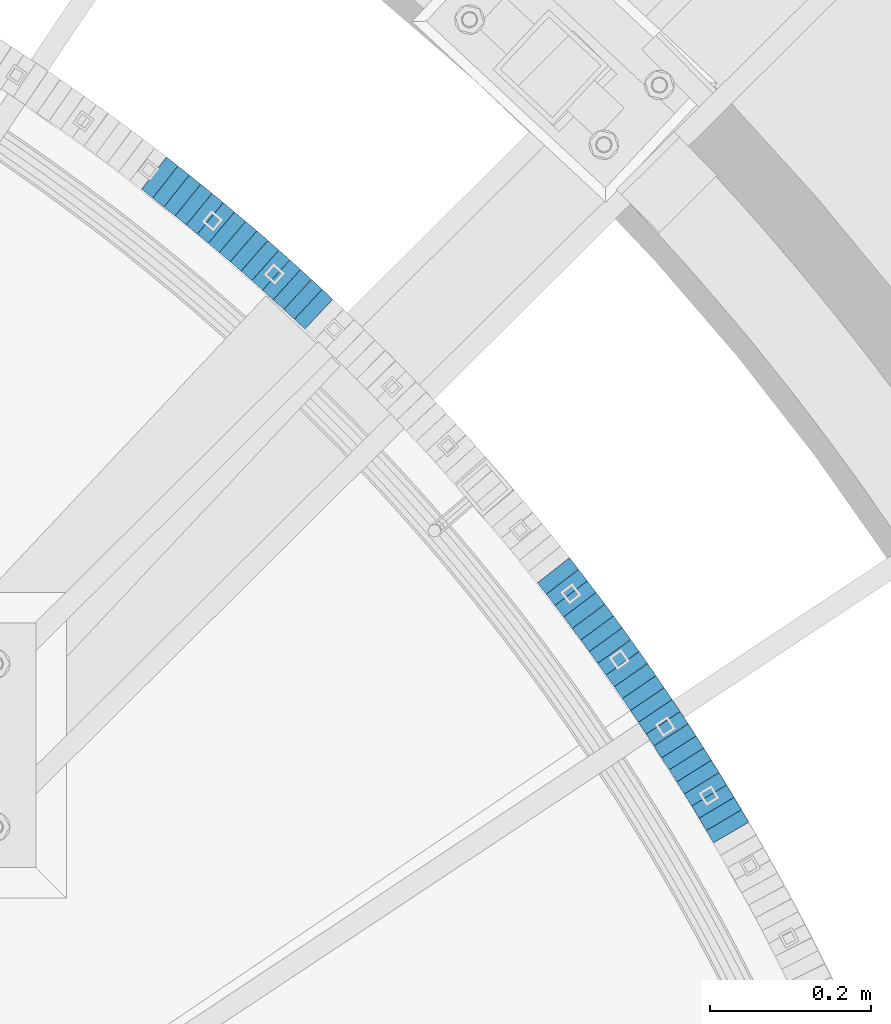
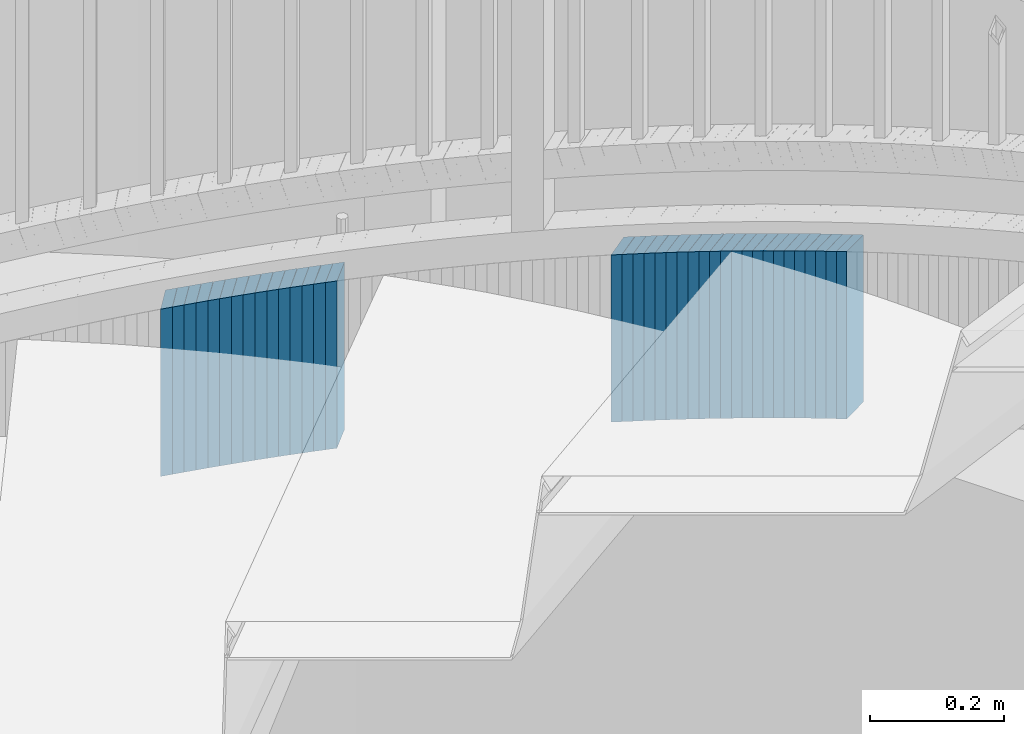
# One storey, part 912 of 975: 37 plates.
"""IFC2X3 building model written with IfcOpenShell, lengths in millimetres."""

from ifc_helpers import new_model, si_unit, frame, origin_with_axes, place, context, subcontext, project, spatial, faceted_brep, material, type_object, element, save


model = new_model("IFC2X3")

# Units and contexts
model_context = context("Model", 3, precision=1e-05, world=origin_with_axes())
body_context = subcontext(model_context, "Body", "Model", "MODEL_VIEW")
ifc_project = project(units=[si_unit("LENGTHUNIT", "METRE", prefix="MILLI"), si_unit("AREAUNIT", "SQUARE_METRE"), si_unit("VOLUMEUNIT", "CUBIC_METRE"), si_unit("MASSUNIT", "GRAM", prefix="KILO"), si_unit("TIMEUNIT", "SECOND"), si_unit("PLANEANGLEUNIT", "RADIAN"), si_unit("SOLIDANGLEUNIT", "STERADIAN"), si_unit("THERMODYNAMICTEMPERATUREUNIT", "DEGREE_CELSIUS"), si_unit("LUMINOUSINTENSITYUNIT", "LUMEN")], contexts=[model_context])

# Site, building, storey
site_placement = place(None, origin_with_axes())
site = spatial("IfcSite", under=ifc_project, at=site_placement, CompositionType="ELEMENT")
building_placement = place(site_placement, origin_with_axes())
building = spatial("IfcBuilding", under=site, at=building_placement, Name="Undefined", CompositionType="ELEMENT")
storey_placement = place(building_placement, origin_with_axes())
storey = spatial("IfcBuildingStorey", under=building, at=storey_placement, Name="Undefined", CompositionType="ELEMENT", Elevation=0.0)

# Plates
ifc_material = material(Name="STEEL/A36")
plate_type = type_object("IfcPlateType", PredefinedType="NOTDEFINED")
plate_1_placement = place(storey_placement, frame((37204.5902551862, 4865.35883614669, 2012.49999999174), z_axis=(0.507020126956712, -0.861934214926406, 0.0), x_axis=(0.0, 0.0, -1.0)))
element("IfcPlate", 1, at=plate_1_placement, inside=storey, type_object=plate_type, material=ifc_material, Name="WALL", context=body_context, shape_type="Brep", body=[
    faceted_brep([(0.0, -25.3999999999724, -1.81898940354586e-11), (-5.69999980926514, -25.3999999999869, 17.750774383554), (-5.69999980926514, 25.3999999999432, 17.750774383534), (0.0, 25.3999999999869, 1.45519152283669e-11), (299.100006103516, -25.3999999999869, 17.750774383554), (299.100006103516, 25.3999999999432, 17.750774383534), (304.799987792969, -25.3999999999724, -1.81898940354586e-11), (304.799987792969, 25.3999999999869, 1.45519152283669e-11)], [[[0, 1, 2, 3]], [[1, 4, 5, 2]], [[4, 6, 7, 5]], [[6, 0, 3, 7]], [[5, 7, 3, 2]], [[6, 4, 1, 0]]]),
])
plate_2_placement = place(storey_placement, frame((37195.4276434617, 4880.76468883828, 2006.79999999174), z_axis=(0.511187555792532, -0.85946918665119, 0.0), x_axis=(0.0, 0.0, -1.0)))
element("IfcPlate", 2, at=plate_2_placement, inside=storey, type_object=plate_type, material=ifc_material, Name="WALL", context=body_context, shape_type="Brep", body=[
    faceted_brep([(0.0, -25.3999999999724, -1.81898940354586e-11), (-5.69999980926514, -25.4000000000378, 17.8044929504049), (-5.69999980926514, 25.4000000000233, 17.8044929504613), (0.0, 25.3999999999869, 1.45519152283669e-11), (299.100006103516, -25.4000000000378, 17.8044929504049), (299.100006103516, 25.4000000000233, 17.8044929504613), (304.799987792969, -25.3999999999724, -1.81898940354586e-11), (304.799987792969, 25.3999999999869, 1.45519152283669e-11)], [[[0, 1, 2, 3]], [[1, 4, 5, 2]], [[4, 6, 7, 5]], [[6, 0, 3, 7]], [[5, 7, 3, 2]], [[6, 4, 1, 0]]]),
])
plate_3_placement = place(storey_placement, frame((37186.2900869338, 4896.02762646858, 2001.19999999174), z_axis=(0.513665415235314, -0.857990583393042, 0.0), x_axis=(0.0, 0.0, -1.0)))
element("IfcPlate", 3, at=plate_3_placement, inside=storey, type_object=plate_type, material=ifc_material, Name="WALL", context=body_context, shape_type="Brep", body=[
    faceted_brep([(0.0, -25.3999999999724, -1.81898940354586e-11), (-5.59999990463257, -25.3999999999141, 17.7158126831655), (-5.59999990463257, 25.3999999999724, 17.71581268308), (0.0, 25.3999999999869, 1.45519152283669e-11), (299.200012207031, -25.3999999999141, 17.7158126831655), (299.200012207031, 25.3999999999724, 17.71581268308), (304.799987792969, -25.3999999999724, -1.81898940354586e-11), (304.799987792969, 25.3999999999869, 1.45519152283669e-11)], [[[0, 1, 2, 3]], [[1, 4, 5, 2]], [[4, 6, 7, 5]], [[6, 0, 3, 7]], [[5, 7, 3, 2]], [[6, 4, 1, 0]]]),
])
plate_4_placement = place(storey_placement, frame((37176.9882196568, 4911.29629053914, 1995.49999999174), z_axis=(0.520305732901602, -0.8539800608385, 0.0), x_axis=(0.0, 0.0, -1.0)))
element("IfcPlate", 4, at=plate_4_placement, inside=storey, type_object=plate_type, material=ifc_material, Name="WALL", context=body_context, shape_type="Brep", body=[
    faceted_brep([(0.0, -25.3999999999724, -1.81898940354586e-11), (-5.69999980926514, -25.4000000001179, 17.6819114684386), (-5.69999980926514, 25.400000000016, 17.681911468515), (0.0, 25.3999999999869, 1.45519152283669e-11), (299.100006103516, -25.4000000001179, 17.6819114684386), (299.100006103516, 25.400000000016, 17.681911468515), (304.799987792969, -25.3999999999724, -1.81898940354586e-11), (304.799987792969, 25.3999999999869, 1.45519152283669e-11)], [[[0, 1, 2, 3]], [[1, 4, 5, 2]], [[4, 6, 7, 5]], [[6, 0, 3, 7]], [[5, 7, 3, 2]], [[6, 4, 1, 0]]]),
])
for number, where, z_axis, x_axis, name in (
    (5, (37167.4201454912, 4926.56828372483, 1989.79999999174), (0.531014126038609, -0.847362967061609, 0.0), (0.0, 0.0, -1.0), "WALL"),
    (6, (37158.0201454751, 4941.56828372472, 1984.09999999174), (0.531014126038609, -0.847362967061609, 0.0), (0.0, 0.0, -1.0), "WALL"),
):
    element("IfcPlate", number, at=place(storey_placement, frame(where, z_axis=z_axis, x_axis=x_axis)), inside=storey, type_object=plate_type, material=ifc_material, Name=name, context=body_context, shape_type="Brep", body=[
        faceted_brep([(0.0, -25.3999999999724, -1.81898940354586e-11), (-5.69999980926514, -25.3999999999724, 17.6954803467033), (-5.69999980926514, 25.4000000000669, 17.6954803467179), (0.0, 25.3999999999869, 1.45519152283669e-11), (299.100006103516, -25.3999999999724, 17.6954803467033), (299.100006103516, 25.4000000000669, 17.6954803467179), (304.799987792969, -25.3999999999724, -1.81898940354586e-11), (304.799987792969, 25.3999999999869, 1.45519152283669e-11)], [[[0, 1, 2, 3]], [[1, 4, 5, 2]], [[4, 6, 7, 5]], [[6, 0, 3, 7]], [[5, 7, 3, 2]], [[6, 4, 1, 0]]]),
    ])
plate_5_placement = place(storey_placement, frame((37148.4142824683, 4956.63575885275, 1978.39999999174), z_axis=(0.537607635043335, -0.843195132067964, 0.0), x_axis=(0.0, 0.0, -1.0)))
element("IfcPlate", 7, at=plate_5_placement, inside=storey, type_object=plate_type, material=ifc_material, Name="WALL", context=body_context, shape_type="Brep", body=[
    faceted_brep([(0.0, -25.3999999999724, -1.81898940354586e-11), (-5.69999980926514, -25.3999999999651, 17.6708793640282), (-5.69999980926514, 25.3999999999942, 17.6708793640191), (0.0, 25.3999999999869, 1.45519152283669e-11), (299.100006103516, -25.3999999999651, 17.6708793640282), (299.100006103516, 25.3999999999942, 17.6708793640191), (304.799987792969, -25.3999999999724, -1.81898940354586e-11), (304.799987792969, 25.3999999999869, 1.45519152283669e-11)], [[[0, 1, 2, 3]], [[1, 4, 5, 2]], [[4, 6, 7, 5]], [[6, 0, 3, 7]], [[5, 7, 3, 2]], [[6, 4, 1, 0]]]),
])
plate_6_placement = place(storey_placement, frame((37138.9142824702, 4971.5357588542, 1972.79999999174), z_axis=(0.537607635043335, -0.843195132067964, 0.0), x_axis=(0.0, 0.0, -1.0)))
element("IfcPlate", 8, at=plate_6_placement, inside=storey, type_object=plate_type, material=ifc_material, Name="WALL", context=body_context, shape_type="Brep", body=[
    faceted_brep([(0.0, -25.3999999999724, -1.81898940354586e-11), (-5.59999990463257, -25.3999999999651, 17.6708793640246), (-5.59999990463257, 25.3999999999942, 17.6708793640119), (0.0, 25.3999999999869, 1.45519152283669e-11), (299.200012207031, -25.3999999999651, 17.6708793640246), (299.200012207031, 25.3999999999942, 17.6708793640119), (304.799987792969, -25.3999999999724, -1.81898940354586e-11), (304.799987792969, 25.3999999999869, 1.45519152283669e-11)], [[[0, 1, 2, 3]], [[1, 4, 5, 2]], [[4, 6, 7, 5]], [[6, 0, 3, 7]], [[5, 7, 3, 2]], [[6, 4, 1, 0]]]),
])
plate_7_placement = place(storey_placement, frame((37129.0409696056, 4986.60385477673, 1967.09999999174), z_axis=(0.548162592686168, -0.836371790521164, 0.0), x_axis=(0.0, 0.0, -1.0)))
element("IfcPlate", 9, at=plate_7_placement, inside=storey, type_object=plate_type, material=ifc_material, Name="WALL", context=body_context, shape_type="Brep", body=[
    faceted_brep([(0.0, -25.3999999999724, -1.81898940354586e-11), (-5.69999980926514, -25.3999999999724, 17.6954803467033), (-5.69999980926514, 25.4000000000669, 17.6954803467179), (0.0, 25.3999999999869, 1.45519152283669e-11), (299.100006103516, -25.3999999999724, 17.6954803467033), (299.100006103516, 25.4000000000669, 17.6954803467179), (304.799987792969, -25.3999999999724, -1.81898940354586e-11), (304.799987792969, 25.3999999999869, 1.45519152283669e-11)], [[[0, 1, 2, 3]], [[1, 4, 5, 2]], [[4, 6, 7, 5]], [[6, 0, 3, 7]], [[5, 7, 3, 2]], [[6, 4, 1, 0]]]),
])
plate_8_placement = place(storey_placement, frame((37119.1312036086, 5001.46990990477, 1961.49999999174), z_axis=(0.554700196030179, -0.832050294467877, 1.48236722452566e-10), x_axis=(0.0, 0.0, -1.0)))
element("IfcPlate", 10, at=plate_8_placement, inside=storey, type_object=plate_type, material=ifc_material, Name="WALL", context=body_context, shape_type="Brep", body=[
    faceted_brep([(0.0, -25.3999999999724, -1.81898940354586e-11), (-5.59999990463257, -25.3999999999651, 17.6708793640246), (-5.59999990463257, 25.3999999999942, 17.6708793640119), (0.0, 25.3999999999869, 1.45519152283669e-11), (299.200012207031, -25.3999999999651, 17.6708793640246), (299.200012207031, 25.3999999999942, 17.6708793640119), (304.799987792969, -25.3999999999724, -1.81898940354586e-11), (304.799987792969, 25.3999999999869, 1.45519152283669e-11)], [[[0, 1, 2, 3]], [[1, 4, 5, 2]], [[4, 6, 7, 5]], [[6, 0, 3, 7]], [[5, 7, 3, 2]], [[6, 4, 1, 0]]]),
])
plate_9_placement = place(storey_placement, frame((37109.2866526589, 5016.13650849619, 1955.79999999174), z_axis=(0.557322187932383, -0.830296319899265, 0.0), x_axis=(0.0, 0.0, -1.0)))
element("IfcPlate", 11, at=plate_9_placement, inside=storey, type_object=plate_type, material=ifc_material, Name="WALL", context=body_context, shape_type="Brep", body=[
    faceted_brep([(0.0, -25.3999999999724, -1.81898940354586e-11), (-5.69999980926514, -25.4000000000815, 17.5840835570707), (-5.69999980926514, 25.4000000000378, 17.5840835571653), (0.0, 25.3999999999869, 1.45519152283669e-11), (299.100006103516, -25.4000000000815, 17.5840835570707), (299.100006103516, 25.4000000000378, 17.5840835571653), (304.799987792969, -25.3999999999724, -1.81898940354586e-11), (304.799987792969, 25.3999999999869, 1.45519152283669e-11)], [[[0, 1, 2, 3]], [[1, 4, 5, 2]], [[4, 6, 7, 5]], [[6, 0, 3, 7]], [[5, 7, 3, 2]], [[6, 4, 1, 0]]]),
])
plate_10_placement = place(storey_placement, frame((37099.0773005664, 5031.0980763962, 1949.99999999174), z_axis=(0.563683128984253, -0.825991119866626, 1.97794634004822e-11), x_axis=(0.0, 0.0, -1.0)))
element("IfcPlate", 12, at=plate_10_placement, inside=storey, type_object=plate_type, material=ifc_material, Name="WALL", context=body_context, shape_type="Brep", body=[
    faceted_brep([(0.0, -25.3999999999724, -1.81898940354586e-11), (-5.80000019073486, -25.3999999999724, 17.9212169647508), (-5.80000019073486, 25.399999999885, 17.9212169646526), (0.0, 25.3999999999869, 1.45519152283669e-11), (299.0, -25.3999999999724, 17.9212169647508), (299.0, 25.399999999885, 17.9212169646526), (304.799987792969, -25.3999999999724, -1.81898940354586e-11), (304.799987792969, 25.3999999999869, 1.45519152283669e-11)], [[[0, 1, 2, 3]], [[1, 4, 5, 2]], [[4, 6, 7, 5]], [[6, 0, 3, 7]], [[5, 7, 3, 2]], [[6, 4, 1, 0]]]),
])
plate_11_placement = place(storey_placement, frame((37088.8112846251, 5045.99433685699, 1944.29999999174), z_axis=(0.567472910754157, -0.823392066733828, 3.25858309224714e-11), x_axis=(0.0, 0.0, -1.0)))
element("IfcPlate", 13, at=plate_11_placement, inside=storey, type_object=plate_type, material=ifc_material, Name="WALL", context=body_context, shape_type="Brep", body=[
    faceted_brep([(0.0, -25.3999999999724, -1.81898940354586e-11), (-5.69999980926514, -25.3999999999505, 17.9744262695713), (-5.69999980926514, 25.4000000000524, 17.9744262695494), (0.0, 25.3999999999869, 1.45519152283669e-11), (299.100006103516, -25.3999999999505, 17.9744262695713), (299.100006103516, 25.4000000000524, 17.9744262695494), (304.799987792969, -25.3999999999724, -1.81898940354586e-11), (304.799987792969, 25.3999999999869, 1.45519152283669e-11)], [[[0, 1, 2, 3]], [[1, 4, 5, 2]], [[4, 6, 7, 5]], [[6, 0, 3, 7]], [[5, 7, 3, 2]], [[6, 4, 1, 0]]]),
])
plate_12_placement = place(storey_placement, frame((37078.3520487749, 5060.822696403, 1938.59999999174), z_axis=(0.576463444084067, -0.817122939119161, 0.0), x_axis=(0.0, 0.0, -1.0)))
element("IfcPlate", 14, at=plate_12_placement, inside=storey, type_object=plate_type, material=ifc_material, Name="WALL", context=body_context, shape_type="Brep", body=[
    faceted_brep([(0.0, -25.3999999999724, -1.81898940354586e-11), (-5.69999980926514, -25.4000000000524, 17.8734436034756), (-5.69999980926514, 25.4000000000888, 17.8734436035884), (0.0, 25.3999999999869, 1.45519152283669e-11), (299.100006103516, -25.4000000000524, 17.8734436034756), (299.100006103516, 25.4000000000888, 17.8734436035884), (304.799987792969, -25.3999999999724, -1.81898940354586e-11), (304.799987792969, 25.3999999999869, 1.45519152283669e-11)], [[[0, 1, 2, 3]], [[1, 4, 5, 2]], [[4, 6, 7, 5]], [[6, 0, 3, 7]], [[5, 7, 3, 2]], [[6, 4, 1, 0]]]),
])
plate_13_placement = place(storey_placement, frame((37068.0520487655, 5075.42269640356, 1932.79999999174), z_axis=(0.576463444084067, -0.817122939119161, 0.0), x_axis=(0.0, 0.0, -1.0)))
element("IfcPlate", 15, at=plate_13_placement, inside=storey, type_object=plate_type, material=ifc_material, Name="WALL", context=body_context, shape_type="Brep", body=[
    faceted_brep([(0.0, -25.3999999999724, -1.81898940354586e-11), (-5.80000019073486, -25.4000000000524, 17.8675689696865), (-5.80000019073486, 25.4000000000888, 17.867568969803), (0.0, 25.3999999999869, 1.45519152283669e-11), (299.0, -25.4000000000524, 17.8675689696865), (299.0, 25.4000000000888, 17.867568969803), (304.799987792969, -25.3999999999724, -1.81898940354586e-11), (304.799987792969, 25.3999999999869, 1.45519152283669e-11)], [[[0, 1, 2, 3]], [[1, 4, 5, 2]], [[4, 6, 7, 5]], [[6, 0, 3, 7]], [[5, 7, 3, 2]], [[6, 4, 1, 0]]]),
])
plate_14_placement = place(storey_placement, frame((37057.4181321885, 5090.21070052087, 1927.09999999174), z_axis=(0.583865180861699, -0.811850633169264, -6.6912434704136e-11), x_axis=(0.0, 0.0, -1.0)))
element("IfcPlate", 16, at=plate_14_placement, inside=storey, type_object=plate_type, material=ifc_material, Name="WALL", context=body_context, shape_type="Brep", body=[
    faceted_brep([(0.0, -25.3999999999724, -1.81898940354586e-11), (-5.69999980926514, -25.3999999999141, 17.9836044311924), (-5.69999980926514, 25.3999999999432, 17.983604431116), (0.0, 25.3999999999869, 1.45519152283669e-11), (299.100006103516, -25.3999999999141, 17.9836044311924), (299.100006103516, 25.3999999999432, 17.983604431116), (304.799987792969, -25.3999999999724, -1.81898940354586e-11), (304.799987792969, 25.3999999999869, 1.45519152283669e-11)], [[[0, 1, 2, 3]], [[1, 4, 5, 2]], [[4, 6, 7, 5]], [[6, 0, 3, 7]], [[5, 7, 3, 2]], [[6, 4, 1, 0]]]),
])
plate_15_placement = place(storey_placement, frame((37046.8205173739, 5104.74549771867, 1921.29999999174), z_axis=(0.589172157703797, -0.80800753003091, 1.76057710632449e-10), x_axis=(0.0, 0.0, -1.0)))
element("IfcPlate", 17, at=plate_15_placement, inside=storey, type_object=plate_type, material=ifc_material, Name="WALL", context=body_context, shape_type="Brep", body=[
    faceted_brep([(0.0, -25.3999999999724, -1.81898940354586e-11), (-5.80000019073486, -25.400000000016, 17.8193721771022), (-5.80000019073486, 25.4000000001179, 17.8193721772113), (0.0, 25.3999999999869, 1.45519152283669e-11), (299.0, -25.400000000016, 17.8193721771022), (299.0, 25.4000000001179, 17.8193721772113), (304.799987792969, -25.3999999999724, -1.81898940354586e-11), (304.799987792969, 25.3999999999869, 1.45519152283669e-11)], [[[0, 1, 2, 3]], [[1, 4, 5, 2]], [[4, 6, 7, 5]], [[6, 0, 3, 7]], [[5, 7, 3, 2]], [[6, 4, 1, 0]]]),
])
plate_16_placement = place(storey_placement, frame((37036.1526829543, 5119.238087597, 1915.59999999174), z_axis=(0.592817428282397, -0.80533688399616, -1.4644820112153e-10), x_axis=(0.0, 0.0, -1.0)))
element("IfcPlate", 18, at=plate_16_placement, inside=storey, type_object=plate_type, material=ifc_material, Name="WALL", context=body_context, shape_type="Brep", body=[
    faceted_brep([(0.0, -25.3999999999724, -1.81898940354586e-11), (-5.69999980926514, -25.4000000000233, 17.8807163238162), (-5.69999980926514, 25.400000000096, 17.8807163239253), (0.0, 25.3999999999869, 1.45519152283669e-11), (299.100006103516, -25.4000000000233, 17.8807163238162), (299.100006103516, 25.400000000096, 17.8807163239253), (304.799987792969, -25.3999999999724, -1.81898940354586e-11), (304.799987792969, 25.3999999999869, 1.45519152283669e-11)], [[[0, 1, 2, 3]], [[1, 4, 5, 2]], [[4, 6, 7, 5]], [[6, 0, 3, 7]], [[5, 7, 3, 2]], [[6, 4, 1, 0]]]),
])
plate_17_placement = place(storey_placement, frame((37025.1659856951, 5133.7884748219, 1909.89999999174), z_axis=(0.602675192946117, -0.797986598764266, 3.15118882099341e-11), x_axis=(0.0, 0.0, -1.0)))
element("IfcPlate", 19, at=plate_17_placement, inside=storey, type_object=plate_type, material=ifc_material, Name="WALL", context=body_context, shape_type="Brep", body=[
    faceted_brep([(0.0, -25.3999999999724, -1.81898940354586e-11), (-5.69999980926514, -25.4000000000087, 17.9245643615468), (-5.69999980926514, 25.3999999999687, 17.9245643615541), (0.0, 25.3999999999869, 1.45519152283669e-11), (299.100006103516, -25.4000000000087, 17.9245643615468), (299.100006103516, 25.3999999999687, 17.9245643615541), (304.799987792969, -25.3999999999724, -1.81898940354586e-11), (304.799987792969, 25.3999999999869, 1.45519152283669e-11)], [[[0, 1, 2, 3]], [[1, 4, 5, 2]], [[4, 6, 7, 5]], [[6, 0, 3, 7]], [[5, 7, 3, 2]], [[6, 4, 1, 0]]]),
])
plate_18_placement = place(storey_placement, frame((37014.3141575053, 5148.05685869153, 1904.09999999174), z_axis=(0.605367471185716, -0.795946119300931, 2.19515641219914e-11), x_axis=(0.0, 0.0, -1.0)))
element("IfcPlate", 20, at=plate_18_placement, inside=storey, type_object=plate_type, material=ifc_material, Name="WALL", context=body_context, shape_type="Brep", body=[
    faceted_brep([(0.0, -25.3999999999724, -1.81898940354586e-11), (-5.80000019073486, -25.3999999999578, 17.8370399475461), (-5.80000019073486, 25.4000000000524, 17.8370399475607), (0.0, 25.3999999999869, 1.45519152283669e-11), (299.0, -25.3999999999578, 17.8370399475461), (299.0, 25.4000000000524, 17.8370399475607), (304.799987792969, -25.3999999999724, -1.81898940354586e-11), (304.799987792969, 25.3999999999869, 1.45519152283669e-11)], [[[0, 1, 2, 3]], [[1, 4, 5, 2]], [[4, 6, 7, 5]], [[6, 0, 3, 7]], [[5, 7, 3, 2]], [[6, 4, 1, 0]]]),
])
plate_19_placement = place(storey_placement, frame((37003.514157496, 5162.25685869354, 1898.39999999174), z_axis=(0.605367471185716, -0.795946119300931, 2.19515641219914e-11), x_axis=(0.0, 0.0, -1.0)))
element("IfcPlate", 21, at=plate_19_placement, inside=storey, type_object=plate_type, material=ifc_material, Name="WALL", context=body_context, shape_type="Brep", body=[
    faceted_brep([(0.0, -25.3999999999724, -1.81898940354586e-11), (-5.69999980926514, -25.3999999999614, 17.8370399475461), (-5.69999980926514, 25.4000000000487, 17.8370399475571), (0.0, 25.3999999999869, 1.45519152283669e-11), (299.100006103516, -25.3999999999614, 17.8370399475461), (299.100006103516, 25.4000000000487, 17.8370399475571), (304.799987792969, -25.3999999999724, -1.81898940354586e-11), (304.799987792969, 25.3999999999869, 1.45519152283669e-11)], [[[0, 1, 2, 3]], [[1, 4, 5, 2]], [[4, 6, 7, 5]], [[6, 0, 3, 7]], [[5, 7, 3, 2]], [[6, 4, 1, 0]]]),
])
plate_20_placement = place(storey_placement, frame((36992.3237069683, 5176.60409868517, 1892.69999999174), z_axis=(0.615101329330327, -0.788448067190265, 4.57119426755526e-11), x_axis=(0.0, 0.0, -1.0)))
element("IfcPlate", 22, at=plate_20_placement, inside=storey, type_object=plate_type, material=ifc_material, Name="WALL", context=body_context, shape_type="Brep", body=[
    faceted_brep([(0.0, -25.3999999999724, -1.81898940354586e-11), (-5.69999980926514, -25.4000000000233, 17.8807163238162), (-5.69999980926514, 25.400000000096, 17.8807163239253), (0.0, 25.3999999999869, 1.45519152283669e-11), (299.100006103516, -25.4000000000233, 17.8807163238162), (299.100006103516, 25.400000000096, 17.8807163239253), (304.799987792969, -25.3999999999724, -1.81898940354586e-11), (304.799987792969, 25.3999999999869, 1.45519152283669e-11)], [[[0, 1, 2, 3]], [[1, 4, 5, 2]], [[4, 6, 7, 5]], [[6, 0, 3, 7]], [[5, 7, 3, 2]], [[6, 4, 1, 0]]]),
])
plate_21_placement = place(storey_placement, frame((36686.9077774295, 5507.96819152022, 1749.29999999174), z_axis=(0.731797897769698, -0.681521706785522, 0.0), x_axis=(0.0, 0.0, -1.0)))
element("IfcPlate", 23, at=plate_21_placement, inside=storey, type_object=plate_type, material=ifc_material, Name="WALL", context=body_context, shape_type="Brep", body=[
    faceted_brep([(0.0, -25.3999999999724, -1.81898940354586e-11), (-5.69999980926514, -25.3999999999578, 17.9047489166387), (-5.69999980926514, 25.3999999999069, 17.9047489165732), (0.0, 25.3999999999869, 1.45519152283669e-11), (299.100006103516, -25.3999999999578, 17.9047489166387), (299.100006103516, 25.3999999999069, 17.9047489165732), (304.799987792969, -25.3999999999724, -1.81898940354586e-11), (304.799987792969, 25.3999999999869, 1.45519152283669e-11)], [[[0, 1, 2, 3]], [[1, 4, 5, 2]], [[4, 6, 7, 5]], [[6, 0, 3, 7]], [[5, 7, 3, 2]], [[6, 4, 1, 0]]]),
])
plate_22_placement = place(storey_placement, frame((36673.8077774265, 5520.16819151824, 1743.49999999174), z_axis=(0.731797897769698, -0.681521706785522, 0.0), x_axis=(0.0, 0.0, -1.0)))
element("IfcPlate", 24, at=plate_22_placement, inside=storey, type_object=plate_type, material=ifc_material, Name="WALL", context=body_context, shape_type="Brep", body=[
    faceted_brep([(0.0, -25.3999999999724, -1.81898940354586e-11), (-5.80000019073486, -25.3999999999614, 17.8966484070224), (-5.80000019073486, 25.3999999999105, 17.896648406906), (0.0, 25.3999999999869, 1.45519152283669e-11), (299.0, -25.3999999999614, 17.8966484070224), (299.0, 25.3999999999105, 17.896648406906), (304.799987792969, -25.3999999999724, -1.81898940354586e-11), (304.799987792969, 25.3999999999869, 1.45519152283669e-11)], [[[0, 1, 2, 3]], [[1, 4, 5, 2]], [[4, 6, 7, 5]], [[6, 0, 3, 7]], [[5, 7, 3, 2]], [[6, 4, 1, 0]]]),
])
plate_23_placement = place(storey_placement, frame((36660.2123187447, 5532.43903012125, 1737.79999999174), z_axis=(0.742460834916594, -0.669889474924748, 0.0), x_axis=(0.0, 0.0, -1.0)))
element("IfcPlate", 25, at=plate_23_placement, inside=storey, type_object=plate_type, material=ifc_material, Name="WALL", context=body_context, shape_type="Brep", body=[
    faceted_brep([(0.0, -25.3999999999724, -1.81898940354586e-11), (-5.69999980926514, -25.4000000000524, 17.9134025573221), (-5.69999980926514, 25.4000000000524, 17.9134025574494), (0.0, 25.3999999999869, 1.45519152283669e-11), (299.100006103516, -25.4000000000524, 17.9134025573221), (299.100006103516, 25.4000000000524, 17.9134025574494), (304.799987792969, -25.3999999999724, -1.81898940354586e-11), (304.799987792969, 25.3999999999869, 1.45519152283669e-11)], [[[0, 1, 2, 3]], [[1, 4, 5, 2]], [[4, 6, 7, 5]], [[6, 0, 3, 7]], [[5, 7, 3, 2]], [[6, 4, 1, 0]]]),
])
plate_24_placement = place(storey_placement, frame((36647.0830150437, 5544.37500277482, 1732.09999999174), z_axis=(0.739940073305354, -0.672672794095961, -8.58849489304701e-11), x_axis=(0.0, 0.0, -1.0)))
element("IfcPlate", 26, at=plate_24_placement, inside=storey, type_object=plate_type, material=ifc_material, Name="WALL", context=body_context, shape_type="Brep", body=[
    faceted_brep([(0.0, -25.3999999999724, -1.81898940354586e-11), (-5.69999980926514, -25.3999999999614, 17.8370399475461), (-5.69999980926514, 25.4000000000487, 17.8370399475571), (0.0, 25.3999999999869, 1.45519152283669e-11), (299.100006103516, -25.3999999999614, 17.8370399475461), (299.100006103516, 25.4000000000487, 17.8370399475571), (304.799987792969, -25.3999999999724, -1.81898940354586e-11), (304.799987792969, 25.3999999999869, 1.45519152283669e-11)], [[[0, 1, 2, 3]], [[1, 4, 5, 2]], [[4, 6, 7, 5]], [[6, 0, 3, 7]], [[5, 7, 3, 2]], [[6, 4, 1, 0]]]),
])
plate_25_placement = place(storey_placement, frame((36633.4631686359, 5556.47253923468, 1726.29999999174), z_axis=(0.747717099182229, -0.664017424161831, 0.0), x_axis=(0.0, 0.0, -1.0)))
element("IfcPlate", 27, at=plate_25_placement, inside=storey, type_object=plate_type, material=ifc_material, Name="WALL", context=body_context, shape_type="Brep", body=[
    faceted_brep([(0.0, -25.3999999999724, -1.81898940354586e-11), (-5.80000019073486, -25.3999999999724, 17.9212169647508), (-5.80000019073486, 25.399999999885, 17.9212169646526), (0.0, 25.3999999999869, 1.45519152283669e-11), (299.0, -25.3999999999724, 17.9212169647508), (299.0, 25.399999999885, 17.9212169646526), (304.799987792969, -25.3999999999724, -1.81898940354586e-11), (304.799987792969, 25.3999999999869, 1.45519152283669e-11)], [[[0, 1, 2, 3]], [[1, 4, 5, 2]], [[4, 6, 7, 5]], [[6, 0, 3, 7]], [[5, 7, 3, 2]], [[6, 4, 1, 0]]]),
])
plate_26_placement = place(storey_placement, frame((36619.9834873957, 5568.34300304988, 1720.59999999174), z_axis=(0.750491265210869, -0.660880368026006, -7.65185177442618e-11), x_axis=(0.0, 0.0, -1.0)))
element("IfcPlate", 28, at=plate_26_placement, inside=storey, type_object=plate_type, material=ifc_material, Name="WALL", context=body_context, shape_type="Brep", body=[
    faceted_brep([(0.0, -25.3999999999724, -1.81898940354586e-11), (-5.69999980926514, -25.3999999999578, 17.853290557905), (-5.69999980926514, 25.4000000000124, 17.8532905578759), (0.0, 25.3999999999869, 1.45519152283669e-11), (299.100006103516, -25.3999999999578, 17.853290557905), (299.100006103516, 25.4000000000124, 17.8532905578759), (304.799987792969, -25.3999999999724, -1.81898940354586e-11), (304.799987792969, 25.3999999999869, 1.45519152283669e-11)], [[[0, 1, 2, 3]], [[1, 4, 5, 2]], [[4, 6, 7, 5]], [[6, 0, 3, 7]], [[5, 7, 3, 2]], [[6, 4, 1, 0]]]),
])
plate_27_placement = place(storey_placement, frame((36606.3323617232, 5580.17502762454, 1714.89999999174), z_axis=(0.755689083086771, -0.654930538075203, 0.0), x_axis=(0.0, 0.0, -1.0)))
element("IfcPlate", 29, at=plate_27_placement, inside=storey, type_object=plate_type, material=ifc_material, Name="WALL", context=body_context, shape_type="Brep", body=[
    faceted_brep([(0.0, -25.3999999999724, -1.81898940354586e-11), (-5.69999980926514, -25.3999999999687, 17.8619709015074), (-5.69999980926514, 25.4000000000415, 17.8619709015402), (0.0, 25.3999999999869, 1.45519152283669e-11), (299.100006103516, -25.3999999999687, 17.8619709015074), (299.100006103516, 25.4000000000415, 17.8619709015402), (304.799987792969, -25.3999999999724, -1.81898940354586e-11), (304.799987792969, 25.3999999999869, 1.45519152283669e-11)], [[[0, 1, 2, 3]], [[1, 4, 5, 2]], [[4, 6, 7, 5]], [[6, 0, 3, 7]], [[5, 7, 3, 2]], [[6, 4, 1, 0]]]),
])
plate_28_placement = place(storey_placement, frame((36592.5803698433, 5591.90570729454, 1709.09999999174), z_axis=(0.760833952037136, -0.648946605991242, -1.96182554645929e-11), x_axis=(0.0, 0.0, -1.0)))
element("IfcPlate", 30, at=plate_28_placement, inside=storey, type_object=plate_type, material=ifc_material, Name="WALL", context=body_context, shape_type="Brep", body=[
    faceted_brep([(0.0, -25.3999999999724, -1.81898940354586e-11), (-5.80000019073486, -25.4000000000415, 17.8751220702761), (-5.80000019073486, 25.4000000000015, 17.8751220703089), (0.0, 25.3999999999869, 1.45519152283669e-11), (299.0, -25.4000000000415, 17.8751220702761), (299.0, 25.4000000000015, 17.8751220703089), (304.799987792969, -25.3999999999724, -1.81898940354586e-11), (304.799987792969, 25.3999999999869, 1.45519152283669e-11)], [[[0, 1, 2, 3]], [[1, 4, 5, 2]], [[4, 6, 7, 5]], [[6, 0, 3, 7]], [[5, 7, 3, 2]], [[6, 4, 1, 0]]]),
])
plate_29_placement = place(storey_placement, frame((36578.7275434916, 5603.5350222257, 1703.39999999174), z_axis=(0.765925090951707, -0.642929821248493, -7.05453260252398e-11), x_axis=(0.0, 0.0, -1.0)))
element("IfcPlate", 31, at=plate_29_placement, inside=storey, type_object=plate_type, material=ifc_material, Name="WALL", context=body_context, shape_type="Brep", body=[
    faceted_brep([(0.0, -25.3999999999724, -1.81898940354586e-11), (-5.69999980926514, -25.4000000000087, 17.8910598754701), (-5.69999980926514, 25.4000000000087, 17.8910598755028), (0.0, 25.3999999999869, 1.45519152283669e-11), (299.100006103516, -25.4000000000087, 17.8910598754701), (299.100006103516, 25.4000000000087, 17.8910598755028), (304.799987792969, -25.3999999999724, -1.81898940354586e-11), (304.799987792969, 25.3999999999869, 1.45519152283669e-11)], [[[0, 1, 2, 3]], [[1, 4, 5, 2]], [[4, 6, 7, 5]], [[6, 0, 3, 7]], [[5, 7, 3, 2]], [[6, 4, 1, 0]]]),
])
plate_30_placement = place(storey_placement, frame((36564.943787744, 5615.00502190928, 1697.69999999174), z_axis=(0.768680984150278, -0.639632351125051, 0.0), x_axis=(0.0, 0.0, -1.0)))
element("IfcPlate", 32, at=plate_30_placement, inside=storey, type_object=plate_type, material=ifc_material, Name="WALL", context=body_context, shape_type="Brep", body=[
    faceted_brep([(0.0, -25.3999999999724, -1.81898940354586e-11), (-5.69999980926514, -25.4000000000669, 17.8227386474155), (-5.69999980926514, 25.3999999999724, 17.8227386474609), (0.0, 25.3999999999869, 1.45519152283669e-11), (299.100006103516, -25.4000000000669, 17.8227386474155), (299.100006103516, 25.3999999999724, 17.8227386474609), (304.799987792969, -25.3999999999724, -1.81898940354586e-11), (304.799987792969, 25.3999999999869, 1.45519152283669e-11)], [[[0, 1, 2, 3]], [[1, 4, 5, 2]], [[4, 6, 7, 5]], [[6, 0, 3, 7]], [[5, 7, 3, 2]], [[6, 4, 1, 0]]]),
])
plate_31_placement = place(storey_placement, frame((36551.0739147678, 5626.46295340917, 1691.99999999174), z_axis=(0.770961751776529, -0.636881446815391, 0.0), x_axis=(0.0, 0.0, -1.0)))
element("IfcPlate", 33, at=plate_31_placement, inside=storey, type_object=plate_type, material=ifc_material, Name="WALL", context=body_context, shape_type="Brep", body=[
    faceted_brep([(0.0, -25.3999999999724, -1.81898940354586e-11), (-5.69999980926514, -25.3999999999578, 17.9047489166387), (-5.69999980926514, 25.3999999999069, 17.9047489165732), (0.0, 25.3999999999869, 1.45519152283669e-11), (299.100006103516, -25.3999999999578, 17.9047489166387), (299.100006103516, 25.3999999999069, 17.9047489165732), (304.799987792969, -25.3999999999724, -1.81898940354586e-11), (304.799987792969, 25.3999999999869, 1.45519152283669e-11)], [[[0, 1, 2, 3]], [[1, 4, 5, 2]], [[4, 6, 7, 5]], [[6, 0, 3, 7]], [[5, 7, 3, 2]], [[6, 4, 1, 0]]]),
])
plate_32_placement = place(storey_placement, frame((36537.103415769, 5637.80256051089, 1686.19999999174), z_axis=(0.776458094539456, -0.630168888016663, -2.13430666917702e-10), x_axis=(0.0, 0.0, -1.0)))
element("IfcPlate", 34, at=plate_32_placement, inside=storey, type_object=plate_type, material=ifc_material, Name="WALL", context=body_context, shape_type="Brep", body=[
    faceted_brep([(0.0, -25.3999999999724, -1.81898940354586e-11), (-5.80000019073486, -25.400000000016, 17.7730140686072), (-5.80000019073486, 25.4000000000742, 17.7730140686326), (0.0, 25.3999999999869, 1.45519152283669e-11), (299.0, -25.400000000016, 17.7730140686072), (299.0, 25.4000000000742, 17.7730140686326), (304.799987792969, -25.3999999999724, -1.81898940354586e-11), (304.799987792969, 25.3999999999869, 1.45519152283669e-11)], [[[0, 1, 2, 3]], [[1, 4, 5, 2]], [[4, 6, 7, 5]], [[6, 0, 3, 7]], [[5, 7, 3, 2]], [[6, 4, 1, 0]]]),
])
plate_33_placement = place(storey_placement, frame((36522.9643802145, 5649.11459266499, 1680.49999999174), z_axis=(0.780868809491731, -0.624695047493549, -4.54620931122918e-10), x_axis=(0.0, 0.0, -1.0)))
element("IfcPlate", 35, at=plate_33_placement, inside=storey, type_object=plate_type, material=ifc_material, Name="WALL", context=body_context, shape_type="Brep", body=[
    faceted_brep([(0.0, -25.3999999999724, -1.81898940354586e-11), (-5.69999980926514, -25.3999999999942, 17.9287471771386), (-5.69999980926514, 25.3999999999796, 17.9287471770876), (0.0, 25.3999999999869, 1.45519152283669e-11), (299.100006103516, -25.3999999999942, 17.9287471771386), (299.100006103516, 25.3999999999796, 17.9287471770876), (304.799987792969, -25.3999999999724, -1.81898940354586e-11), (304.799987792969, 25.3999999999869, 1.45519152283669e-11)], [[[0, 1, 2, 3]], [[1, 4, 5, 2]], [[4, 6, 7, 5]], [[6, 0, 3, 7]], [[5, 7, 3, 2]], [[6, 4, 1, 0]]]),
])
plate_34_placement = place(storey_placement, frame((36508.8775421076, 5660.2837524709, 1674.79999999174), z_axis=(0.783591635630207, -0.621276225660034, -2.42480524548227e-10), x_axis=(0.0, 0.0, -1.0)))
element("IfcPlate", 36, at=plate_34_placement, inside=storey, type_object=plate_type, material=ifc_material, Name="WALL", context=body_context, shape_type="Brep", body=[
    faceted_brep([(0.0, -25.3999999999724, -1.81898940354586e-11), (-5.69999980926514, -25.4000000000524, 17.8734436034756), (-5.69999980926514, 25.4000000000888, 17.8734436035884), (0.0, 25.3999999999869, 1.45519152283669e-11), (299.100006103516, -25.4000000000524, 17.8734436034756), (299.100006103516, 25.4000000000888, 17.8734436035884), (304.799987792969, -25.3999999999724, -1.81898940354586e-11), (304.799987792969, 25.3999999999869, 1.45519152283669e-11)], [[[0, 1, 2, 3]], [[1, 4, 5, 2]], [[4, 6, 7, 5]], [[6, 0, 3, 7]], [[5, 7, 3, 2]], [[6, 4, 1, 0]]]),
])
plate_35_placement = place(storey_placement, frame((36494.7897934016, 5671.35301072238, 1669.09999999174), z_axis=(0.786318338803255, -0.617821551956298, 5.58256942895241e-11), x_axis=(0.0, 0.0, -1.0)))
element("IfcPlate", 37, at=plate_35_placement, inside=storey, type_object=plate_type, material=ifc_material, Name="WALL", context=body_context, shape_type="Brep", body=[
    faceted_brep([(0.0, -25.3999999999724, -1.81898940354586e-11), (-5.69999980926514, -25.4000000000378, 17.8044929504049), (-5.69999980926514, 25.4000000000233, 17.8044929504613), (0.0, 25.3999999999869, 1.45519152283669e-11), (299.100006103516, -25.4000000000378, 17.8044929504049), (299.100006103516, 25.4000000000233, 17.8044929504613), (304.799987792969, -25.3999999999724, -1.81898940354586e-11), (304.799987792969, 25.3999999999869, 1.45519152283669e-11)], [[[0, 1, 2, 3]], [[1, 4, 5, 2]], [[4, 6, 7, 5]], [[6, 0, 3, 7]], [[5, 7, 3, 2]], [[6, 4, 1, 0]]]),
])

save(model, "model.ifc")
